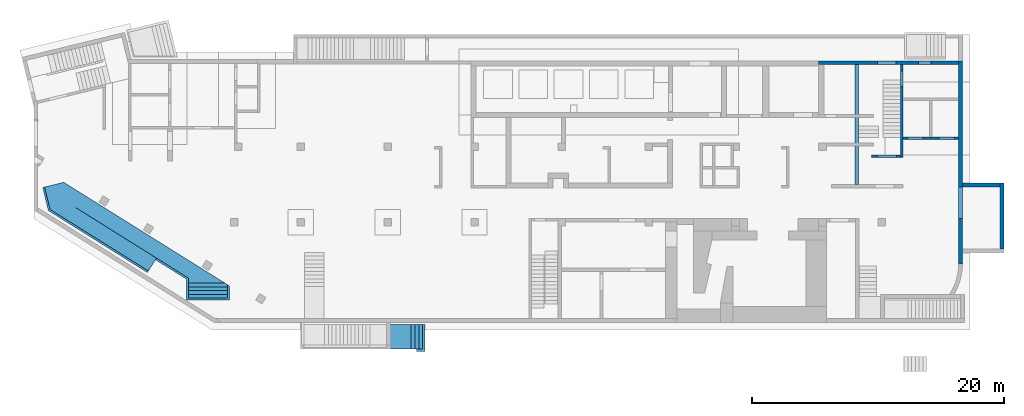
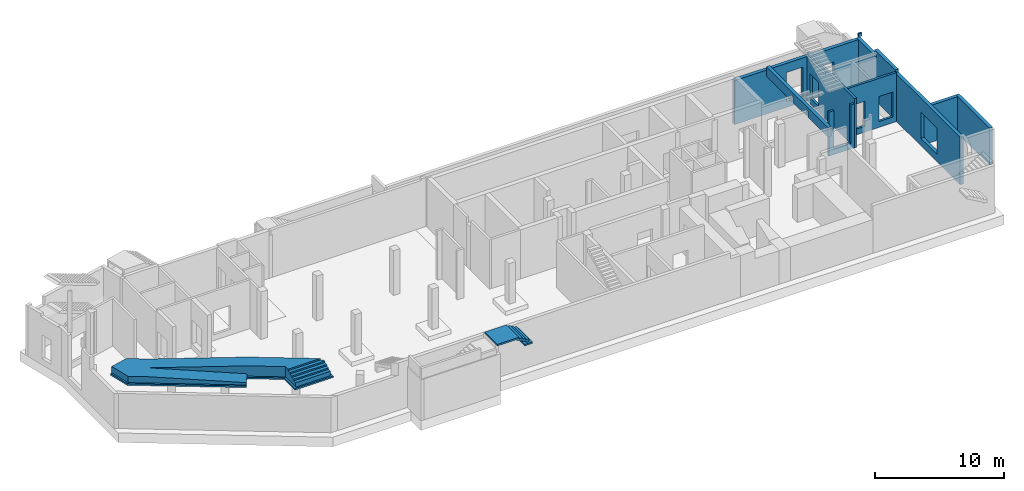
# One storey, part 8 of 9: 8 walls, 2 stairs, 6 openings.
"""IFC4 building model written with IfcOpenShell, lengths in millimetres."""

import ifcopenshell
import ifcopenshell.guid

model = None  # the IFC model being written
_history = None  # IfcOwnerHistory: only IFC2X3 demands one
_inside = {}  # id of a spatial element -> (the spatial element, [elements in it])
_under = {}  # id of a project, library or spatial element -> (it, [spatial elements below it])
_declared = {}  # id of a project -> (the project, [libraries it declares])
_typed = {}  # id of a type object -> (the type object, [elements of that type])
_made_of = {}  # id of a material, layer set ... -> (it, [elements and type objects made of it])


def new_model(schema):
    """Start an empty IFC model of exactly this schema.

    Asked for "IFC4X3", IfcOpenShell would pick the latest addendum, in which some entities
    have other attributes; the version numbers below select the first issue.
    IFC2X3 requires an IfcOwnerHistory on every rooted entity: one is made here for all.
    """
    global model, _history
    if schema == "IFC4X3":
        model = ifcopenshell.file(schema_version=(4, 3, 0, 0))
    else:
        model = ifcopenshell.file(schema=schema)
    _inside.clear()
    _under.clear()
    _declared.clear()
    _typed.clear()
    _made_of.clear()
    _history = None
    if model.schema == "IFC2X3":
        org = make("IfcOrganization", Name="unknown")
        user = make(
            "IfcPersonAndOrganization",
            ThePerson=make("IfcPerson", FamilyName="unknown"),
            TheOrganization=org,
        )
        app = make(
            "IfcApplication",
            ApplicationDeveloper=org,
            Version="unknown",
            ApplicationFullName="unknown",
            ApplicationIdentifier="unknown",
        )
        _history = make(
            "IfcOwnerHistory",
            OwningUser=user,
            OwningApplication=app,
            ChangeAction="ADDED",
            CreationDate=0,
        )
    return model


def make(cls, **values):
    """One entity of the class cls with the attributes given. An attribute that is None is left unset."""
    return model.create_entity(
        cls, **{name: value for name, value in values.items() if value is not None}
    )


def entity(cls, *values):
    """Any entity or typed value of the class cls, its attributes in the order of the schema. None: left unset."""
    e = model.create_entity(cls)
    for i, value in enumerate(values):
        if value is not None:
            e[i] = value
    return e


def rooted(cls, **values):
    """An entity with a GlobalId (a new one), such as an element, a storey or a relation."""
    return make(cls, GlobalId=ifcopenshell.guid.new(), OwnerHistory=_history, **values)


def si_unit(unit_type, name, prefix=None):
    """IfcSIUnit, for example si_unit("LENGTHUNIT", "METRE", prefix="MILLI")."""
    return make("IfcSIUnit", UnitType=unit_type, Prefix=prefix, Name=name)


def converted_unit(unit_type, name, factor, base, dimensions=None, offset=None):
    """IfcConversionBasedUnit, such as the inch: factor (a typed value) times the base unit."""
    return make(
        "IfcConversionBasedUnit"
        if offset is None
        else "IfcConversionBasedUnitWithOffset",
        ConversionOffset=offset,
        Dimensions=None
        if dimensions is None
        else entity("IfcDimensionalExponents", *dimensions),
        UnitType=unit_type,
        Name=name,
        ConversionFactor=make(
            "IfcMeasureWithUnit", ValueComponent=factor, UnitComponent=base
        ),
    )


def derived_unit(unit_type, elements):
    """IfcDerivedUnit: a product of units, each with its exponent."""
    return make(
        "IfcDerivedUnit",
        Elements=[
            make("IfcDerivedUnitElement", Unit=unit, Exponent=power)
            for unit, power in elements
        ],
        UnitType=unit_type,
    )


def assignment(units):
    """IfcUnitAssignment: the units of a project."""
    return None if units is None else make("IfcUnitAssignment", Units=units)


def point(xyz):
    """IfcCartesianPoint."""
    return None if xyz is None else make("IfcCartesianPoint", Coordinates=xyz)


def direction(xyz):
    """IfcDirection."""
    return None if xyz is None else make("IfcDirection", DirectionRatios=xyz)


def frame(location, z_axis=None, x_axis=None):
    """IfcAxis2Placement3D, a coordinate frame: its origin and axes. An axis left out is left unset."""
    return make(
        "IfcAxis2Placement3D",
        Location=point(location),
        Axis=direction(z_axis),
        RefDirection=direction(x_axis),
    )


def origin():
    """The frame at (0, 0, 0) with its axes left unset."""
    return frame((0.0, 0.0, 0.0))


def place(relative_to, where):
    """IfcLocalPlacement: puts the frame where relative to a parent placement (None: the world)."""
    return make(
        "IfcLocalPlacement", PlacementRelTo=relative_to, RelativePlacement=where
    )


def context(
    kind, dimensions, precision=None, world=None, true_north=None, identifier=None
):
    """IfcGeometricRepresentationContext, for example the 3D "Model" context."""
    return make(
        "IfcGeometricRepresentationContext",
        ContextIdentifier=identifier,
        ContextType=kind,
        CoordinateSpaceDimension=dimensions,
        Precision=precision,
        WorldCoordinateSystem=world,
        TrueNorth=true_north,
    )


def subcontext(parent, identifier, kind, view, scale=None):
    """IfcGeometricRepresentationSubContext, for example "Body" below "Model"."""
    return make(
        "IfcGeometricRepresentationSubContext",
        ContextIdentifier=identifier,
        ContextType=kind,
        ParentContext=parent,
        TargetScale=scale,
        TargetView=view,
    )


def project(units=None, contexts=None):
    """IfcProject with its units and contexts."""
    return rooted(
        "IfcProject",
        Name="project",
        RepresentationContexts=contexts,
        UnitsInContext=assignment(units),
    )


def spatial(cls, under=None, at=None, **own):
    """A site, building, storey or space (cls), placed at a placement, below another one or the project."""
    s = rooted(cls, ObjectPlacement=at, **own)
    if under is not None:
        _under.setdefault(under.id(), (under, []))[1].append(s)
    return s


def point_list(points):
    """IfcCartesianPointList2D or 3D."""
    cls = (
        "IfcCartesianPointList2D" if len(points[0]) == 2 else "IfcCartesianPointList3D"
    )
    return make(cls, CoordList=points)


def indexed_curve(points, segments=None, self_intersect=None):
    """IfcIndexedPolyCurve: lines and arcs through numbered points (the first is 1)."""
    return make(
        "IfcIndexedPolyCurve",
        Points=point_list(points),
        Segments=segments,
        SelfIntersect=self_intersect,
    )


def outline(outer, holes=None, kind="AREA"):
    """IfcArbitraryClosedProfileDef: a profile drawn as a closed curve; with holes, ...WithVoids."""
    if holes is None:
        return make("IfcArbitraryClosedProfileDef", ProfileType=kind, OuterCurve=outer)
    return make(
        "IfcArbitraryProfileDefWithVoids",
        ProfileType=kind,
        OuterCurve=outer,
        InnerCurves=holes,
    )


def extrude(swept, where, along, depth):
    """IfcExtrudedAreaSolid: the profile swept, set in the frame where, extruded along a direction by depth."""
    return make(
        "IfcExtrudedAreaSolid",
        SweptArea=swept,
        Position=where,
        ExtrudedDirection=direction(along),
        Depth=depth,
    )


def polygons(points, faces, closed=None, point_numbers=None):
    """IfcPolygonalFaceSet: a face is its outer loop, then its inner loops; points numbered from 1."""
    made = []
    for loops in faces:
        if len(loops) == 1:
            made.append(make("IfcIndexedPolygonalFace", CoordIndex=loops[0]))
        else:
            made.append(
                make(
                    "IfcIndexedPolygonalFaceWithVoids",
                    CoordIndex=loops[0],
                    InnerCoordIndices=loops[1:],
                )
            )
    return make(
        "IfcPolygonalFaceSet",
        Coordinates=point_list(points),
        Closed=closed,
        Faces=made,
        PnIndex=point_numbers,
    )


def shape(context_of_items, identifier, shape_type, items):
    """IfcShapeRepresentation: the items that make up one representation, for example the "Body"."""
    return make(
        "IfcShapeRepresentation",
        ContextOfItems=context_of_items,
        RepresentationIdentifier=identifier,
        RepresentationType=shape_type,
        Items=items,
    )


def material(Name=None, Category=None):
    """IfcMaterial."""
    return make("IfcMaterial", Name=Name, Category=Category)


def made_of(thing, what):
    """Note that an element or type object is made of a material, layer set ...; save() writes the relation."""
    if what is not None:
        _made_of.setdefault(what.id(), (what, []))[1].append(thing)
    return thing


def type_object(cls, material=None, **own):
    """A type object (cls), such as IfcWallType, which elements share."""
    return made_of(rooted(cls, **own), material)


def element(
    cls,
    number,
    at=None,
    inside=None,
    cuts=None,
    type_object=None,
    material=None,
    context=None,
    identifier="Body",
    shape_type=None,
    held_by="IfcProductDefinitionShape",
    body=None,
    shapes=None,
    **own,
):
    """One element of the class cls, such as IfcWall. Its Tag is "e" and its number.

    at: its placement. inside: the storey or other place that contains it. cuts: it is an
    opening in that element (IfcRelVoidsElement). A single representation is given by context,
    identifier, shape_type and body (its items); several are given by shapes. held_by: the class
    of the entity that holds the representations. save() writes the other relations.
    """
    e = rooted(cls, Tag="e%d" % number, ObjectPlacement=at, **own)
    if body is not None:
        shapes = [shape(context, identifier, shape_type, body)]
    if shapes is not None:
        e.Representation = make(held_by, Representations=shapes)
    if inside is not None:
        _inside.setdefault(inside.id(), (inside, []))[1].append(e)
    if cuts is not None:
        rooted(
            "IfcRelVoidsElement", RelatingBuildingElement=cuts, RelatedOpeningElement=e
        )
    if type_object is not None:
        _typed.setdefault(type_object.id(), (type_object, []))[1].append(e)
    return made_of(e, material)


def aggregate(whole, parts):
    """IfcRelAggregates: a whole, such as a stair, and the parts it consists of."""
    return rooted("IfcRelAggregates", RelatingObject=whole, RelatedObjects=parts)


def save(model, path):
    """Write the relations noted so far, then the file.

    IfcRelAggregates (storeys below a building ...), IfcRelContainedInSpatialStructure (elements
    in a storey), IfcRelDefinesByType, IfcRelAssociatesMaterial and IfcRelDeclares: one each for
    every whole, place, type object, material and project.
    """
    for whole, parts in _under.values():
        aggregate(whole, parts)
    for where, things in _inside.values():
        rooted(
            "IfcRelContainedInSpatialStructure",
            RelatedElements=things,
            RelatingStructure=where,
        )
    for kind, things in _typed.values():
        rooted("IfcRelDefinesByType", RelatedObjects=things, RelatingType=kind)
    for what, things in _made_of.values():
        rooted("IfcRelAssociatesMaterial", RelatedObjects=things, RelatingMaterial=what)
    for by, libraries in _declared.values():
        rooted("IfcRelDeclares", RelatingContext=by, RelatedDefinitions=libraries)
    model.write(path)


model = new_model("IFC4")

# Units and contexts
model_context = context("Model", 3, precision=0.01, world=origin(), true_north=direction((6.12303176911189e-17, 1.0)))
plan_context = context("Plan", 3, precision=0.01, world=origin(), true_north=direction((6.12303176911189e-17, 1.0)))
body_context = subcontext(model_context, "Body", "Model", "MODEL_VIEW")
ifc_project = project(units=[si_unit("LENGTHUNIT", "METRE", prefix="MILLI"), si_unit("AREAUNIT", "SQUARE_METRE"), si_unit("VOLUMEUNIT", "CUBIC_METRE"), converted_unit("PLANEANGLEUNIT", "DEGREE", entity("IfcRatioMeasure", 0.0174532925199433), si_unit("PLANEANGLEUNIT", "RADIAN"), dimensions=[0, 0, 0, 0, 0, 0, 0]), si_unit("MASSUNIT", "GRAM", prefix="KILO"), derived_unit("MASSDENSITYUNIT", [(si_unit("MASSUNIT", "GRAM", prefix="KILO"), 1), (si_unit("LENGTHUNIT", "METRE"), -3)]), derived_unit("MOMENTOFINERTIAUNIT", [(si_unit("LENGTHUNIT", "METRE"), 4)]), si_unit("TIMEUNIT", "SECOND"), si_unit("FREQUENCYUNIT", "HERTZ"), si_unit("THERMODYNAMICTEMPERATUREUNIT", "DEGREE_CELSIUS"), derived_unit("THERMALTRANSMITTANCEUNIT", [(si_unit("MASSUNIT", "GRAM", prefix="KILO"), 1), (si_unit("THERMODYNAMICTEMPERATUREUNIT", "KELVIN"), -1), (si_unit("TIMEUNIT", "SECOND"), -3)]), derived_unit("VOLUMETRICFLOWRATEUNIT", [(si_unit("LENGTHUNIT", "METRE"), 3), (si_unit("TIMEUNIT", "SECOND"), -1)]), derived_unit("MASSFLOWRATEUNIT", [(si_unit("MASSUNIT", "GRAM", prefix="KILO"), 1), (si_unit("TIMEUNIT", "SECOND"), -1)]), derived_unit("ROTATIONALFREQUENCYUNIT", [(si_unit("TIMEUNIT", "SECOND"), -1)]), si_unit("ELECTRICCURRENTUNIT", "AMPERE"), si_unit("ELECTRICVOLTAGEUNIT", "VOLT"), si_unit("POWERUNIT", "WATT"), si_unit("FORCEUNIT", "NEWTON", prefix="KILO"), si_unit("ILLUMINANCEUNIT", "LUX"), si_unit("LUMINOUSFLUXUNIT", "LUMEN"), si_unit("LUMINOUSINTENSITYUNIT", "CANDELA"), derived_unit("USERDEFINED", [(si_unit("MASSUNIT", "GRAM", prefix="KILO"), -1), (si_unit("LENGTHUNIT", "METRE"), -2), (si_unit("TIMEUNIT", "SECOND"), 3), (si_unit("LUMINOUSFLUXUNIT", "LUMEN"), 1)]), derived_unit("LINEARVELOCITYUNIT", [(si_unit("LENGTHUNIT", "METRE"), 1), (si_unit("TIMEUNIT", "SECOND"), -1)]), si_unit("PRESSUREUNIT", "PASCAL"), derived_unit("USERDEFINED", [(si_unit("LENGTHUNIT", "METRE"), -2), (si_unit("MASSUNIT", "GRAM", prefix="KILO"), 1), (si_unit("TIMEUNIT", "SECOND"), -2)]), derived_unit("LINEARFORCEUNIT", [(si_unit("MASSUNIT", "GRAM", prefix="KILO"), 1), (si_unit("LENGTHUNIT", "METRE"), 1), (si_unit("TIMEUNIT", "SECOND"), -2), (si_unit("LENGTHUNIT", "METRE"), -1)]), derived_unit("PLANARFORCEUNIT", [(si_unit("MASSUNIT", "GRAM", prefix="KILO"), 1), (si_unit("LENGTHUNIT", "METRE"), 1), (si_unit("TIMEUNIT", "SECOND"), -2), (si_unit("LENGTHUNIT", "METRE"), -2)])], contexts=[model_context, plan_context])

# Site, building, storey
site_placement = place(None, origin())
site = spatial("IfcSite", under=ifc_project, at=site_placement, CompositionType="ELEMENT")
building_placement = place(site_placement, origin())
building = spatial("IfcBuilding", under=site, at=building_placement, CompositionType="ELEMENT")
storey_placement = place(building_placement, frame((0.0, 0.0, -4900.0)))
storey = spatial("IfcBuildingStorey", under=building, at=storey_placement, CompositionType="ELEMENT", Elevation=-4900.0)

# Wall, openings
ifc_material_1 = material()
wall_type_1 = type_object("IfcWallType", PredefinedType="STANDARD")
wall_1_placement = place(storey_placement, frame((68970.0002685547, 14369.999226356, 0.0)))
wall_1 = element("IfcWall", 1, at=wall_1_placement, inside=storey, type_object=wall_type_1, material=ifc_material_1, PredefinedType="NOTDEFINED", context=body_context, shape_type="Tessellation", body=[
    polygons([(2.81053507844076e-12, -100.000000000001, 0.0), (4399.99999999999, -99.9999999999989, 0.0), (4399.99999999999, -99.9999999999989, 4650.0), (2.81053507844076e-12, -100.000000000001, 4650.0), (329.999999999988, -100.000000000003, 2919.99999999804), (1569.99999999999, -100.000000000001, 2919.99999999804), (1569.99999999999, -100.000000000001, 550.0), (329.999999999988, -100.000000000003, 550.0), (2829.99999999998, -100.000000000001, 2919.99999999804), (4069.99999999998, -100.000000000001, 2919.99999999804), (4069.99999999998, -100.000000000001, 550.0), (2829.99999999998, -100.000000000001, 550.0), (4399.99999999999, 99.9999999999989, 0.0), (2.12143781434178e-12, 99.9999999999968, 0.0), (2.12143781434178e-12, 99.9999999999968, 4650.0), (2099.99999999998, 99.9999999999989, 4650.0), (2299.99999999997, 99.9999999999968, 4650.0), (4399.99999999999, 99.9999999999989, 4650.0), (1569.99999999999, 99.9999999999989, 2919.99999999804), (329.999999999996, 99.9999999999968, 2919.99999999804), (329.999999999996, 99.9999999999968, 550.0), (1569.99999999999, 99.9999999999989, 550.0), (4069.99999999998, 99.9999999999989, 2919.99999999804), (2829.99999999998, 99.9999999999968, 2919.99999999804), (2829.99999999998, 99.9999999999968, 550.0), (4069.99999999998, 99.9999999999989, 550.0)], [[[1, 2, 3, 4], [5, 6, 7, 8], [9, 10, 11, 12]], [[13, 14, 15, 16, 17, 18], [19, 20, 21, 22], [23, 24, 25, 26]], [[2, 1, 14, 13]], [[4, 3, 18, 17, 16, 15]], [[3, 2, 13, 18]], [[1, 4, 15, 14]], [[5, 20, 19, 6]], [[6, 19, 22, 7]], [[7, 22, 21, 8]], [[20, 5, 8, 21]], [[23, 10, 9, 24]], [[12, 25, 24, 9]], [[25, 12, 11, 26]], [[26, 11, 10, 23]]], closed=True),
])
opening_1_placement = place(wall_1_placement, frame((-68970.0002685547, -14369.999226356, 0.0)))
element("IfcOpeningElement", 2, at=opening_1_placement, cuts=wall_1, PredefinedType="OPENING", context=body_context, shape_type="SweptSolid", body=[
    extrude(outline(indexed_curve([(-619.999999999998, -1184.99999999902), (620.000000000006, -1184.99999999902), (620.000000000006, 1184.99999999902), (-619.999999999998, 1184.99999999902), (-619.999999999998, -1184.99999999902)], self_intersect=False)), frame((69920.0002685547, 14169.999226354, 1735.0), z_axis=(0.0, 1.0, 0.0), x_axis=(1.0, 0.0, 0.0)), (0.0, 0.0, 1.0), 400.000000001943),
])
opening_2_placement = place(wall_1_placement, frame((-68970.0002685547, -14369.999226356, 0.0)))
element("IfcOpeningElement", 3, at=opening_2_placement, cuts=wall_1, PredefinedType="OPENING", context=body_context, shape_type="SweptSolid", body=[
    extrude(outline(indexed_curve([(-1184.99999999902, -619.999999999998), (1184.99999999902, -619.999999999998), (1184.99999999902, 619.999999999998), (-1184.99999999902, 619.999999999998), (-1184.99999999902, -619.999999999998)], self_intersect=False)), frame((72420.0002685547, 14169.9992263559, 1735.0), z_axis=(0.0, 1.0, 0.0), x_axis=(0.0, 0.0, -1.0)), (0.0, 0.0, 1.0), 400.000000001943),
])

# Wall, opening
wall_2_placement = place(storey_placement, frame((68870.0002685547, 20199.999226356, 0.0), z_axis=(0.0, 0.0, 1.0), x_axis=(0.0, -1.0, 0.0)))
wall_2 = element("IfcWall", 4, at=wall_2_placement, inside=storey, type_object=wall_type_1, material=ifc_material_1, PredefinedType="NOTDEFINED", context=body_context, shape_type="Tessellation", body=[
    polygons([(0.0, -100.000000000003, 0.0), (7169.99999999999, -99.9999999999902, 0.0), (7369.99999999999, -99.9999999999983, 0.0), (7369.99999999999, -99.9999999999983, 4170.0), (7369.99999999999, -99.9999999999983, 4650.0), (0.0, -100.000000000003, 4650.0), (0.0, -100.000000000003, 4420.0), (2830.00000000002, -100.000000000012, 4420.0), (2830.00000000002, -100.000000000012, 4170.0), (0.0, -100.000000000003, 4170.0), (500.000000000003, -100.000000000001, 2829.99999999805), (1750.0, -99.9999999999977, 2829.99999999804), (1750.0, -99.9999999999977, 550.0), (500.000000000003, -100.000000000001, 550.0), (7369.99999999999, 99.9999999999996, 0.0), (5930.00000000002, 100.000000000004, 0.0), (5730.00000000002, 100.000000000003, 0.0), (2830.00000000051, 100.000000000003, 0.0), (2630.00000000051, 100.000000000003, 0.0), (-4.33146851719357e-12, 100.000000000004, 0.0), (-4.33146851719357e-12, 100.000000000004, 4170.0), (2630.00000000051, 100.000000000003, 4170.0), (2830.00000000002, 100.000000000012, 4170.0), (2830.00000000002, 100.000000000012, 4420.0), (2630.00000000051, 100.000000000003, 4420.0), (-4.33146851719357e-12, 100.000000000004, 4420.0), (-4.33146851719357e-12, 100.000000000004, 4650.0), (2630.00000000051, 100.000000000003, 4650.0), (2830.00000000051, 100.000000000003, 4650.0), (5730.00000000002, 100.000000000003, 4650.0), (5930.00000000002, 100.000000000004, 4650.0), (7369.99999999999, 99.9999999999996, 4650.0), (1749.99999999999, 100.000000000009, 2829.99999999804), (499.999999999999, 100.000000000005, 2829.99999999805), (499.999999999999, 100.000000000005, 550.0), (1749.99999999999, 100.000000000009, 550.0)], [[[1, 2, 3, 4, 5, 6, 7, 8, 9, 10], [11, 12, 13, 14]], [[15, 16, 17, 18, 19, 20, 21, 22, 23, 24, 25, 26, 27, 28, 29, 30, 31, 32], [33, 34, 35, 36]], [[3, 2, 1, 20, 19, 18, 17, 16, 15]], [[6, 5, 32, 31, 30, 29, 28, 27]], [[5, 4, 3, 15, 32]], [[20, 1, 10, 21]], [[11, 34, 33, 12]], [[36, 13, 12, 33]], [[13, 36, 35, 14]], [[14, 35, 34, 11]], [[9, 23, 22, 21, 10]], [[24, 8, 7, 26, 25]], [[23, 9, 8, 24]], [[6, 27, 26, 7]]], closed=True),
])
opening_3_placement = place(wall_2_placement, frame((20199.999226356, -68870.0002685547, 0.0), z_axis=(0.0, 0.0, 1.0), x_axis=(0.0, 1.0, 0.0)))
element("IfcOpeningElement", 5, at=opening_3_placement, cuts=wall_2, PredefinedType="OPENING", context=body_context, shape_type="SweptSolid", body=[
    extrude(outline(indexed_curve([(-624.999999999999, -1139.99999999902), (624.999999999999, -1139.99999999902), (624.999999999999, 1139.99999999902), (-624.999999999999, 1139.99999999902), (-624.999999999999, -1139.99999999902)], self_intersect=False)), frame((68670.0002685528, 19074.999226356, 1690.0), z_axis=(1.0, 0.0, 0.0), x_axis=(0.0, -1.0, 0.0)), (0.0, 0.0, 1.0), 400.000000001936),
])

wall_3_placement = place(storey_placement, frame((68770.0002685547, 12929.999226356, 0.0), z_axis=(0.0, 0.0, 1.0), x_axis=(-1.0, 0.0, 0.0)))
wall_3 = element("IfcWall", 6, at=wall_3_placement, inside=storey, type_object=wall_type_1, material=ifc_material_1, PredefinedType="NOTDEFINED", context=body_context, shape_type="Tessellation", body=[
    polygons([(9.8127816513605e-13, -99.9999999999989, 0.0), (2300.00000000003, -99.9999999999989, 0.0), (2300.00000000003, -99.9999999999989, 4170.0), (1830.00000000004, -99.9999999999989, 4170.0), (1830.00000000004, -99.9999999999989, 550.0), (330.00000000003, -99.9999999999968, 550.0), (330.00000000003, -99.9999999999968, 4170.0), (9.8127816513605e-13, -99.9999999999989, 4170.0), (2300.00000000003, 100.000000000001, 0.0), (8.96430781706574e-12, 100.000000000001, 0.0), (8.96430781706574e-12, 100.000000000001, 4170.0), (330.000000000029, 100.000000000003, 4170.0), (330.000000000029, 100.000000000003, 550.0), (1830.00000000003, 100.000000000001, 550.0), (1830.00000000003, 100.000000000001, 4170.0), (2300.00000000003, 100.000000000001, 4170.0)], [[[1, 2, 3, 4, 5, 6, 7, 8]], [[9, 10, 11, 12, 13, 14, 15, 16]], [[2, 1, 10, 9]], [[3, 2, 9, 16]], [[3, 16, 15, 4]], [[1, 8, 11, 10]], [[14, 5, 4, 15]], [[5, 14, 13, 6]], [[6, 13, 12, 7]], [[11, 8, 7, 12]]], closed=True),
])
opening_4_placement = place(wall_3_placement, frame((68770.0002685547, 12929.999226356, 0.0), z_axis=(0.0, 0.0, 1.0), x_axis=(-1.0, 0.0, 0.0)))
element("IfcOpeningElement", 7, at=opening_4_placement, cuts=wall_3, PredefinedType="OPENING", context=body_context, shape_type="SweptSolid", body=[
    extrude(outline(indexed_curve([(-749.999999999994, -1809.99999999902), (750.000000000003, -1809.99999999902), (750.000000000003, 1809.99999999902), (-749.999999999994, 1809.99999999902), (-749.999999999994, -1809.99999999902)], self_intersect=False)), frame((67690.0002685547, 13129.9992263579, 2360.0), z_axis=(0.0, -1.0, 0.0), x_axis=(-1.0, 0.0, 0.0)), (0.0, 0.0, 1.0), 400.000000001943),
])

# Walls
wall_type_2 = type_object("IfcWallType", PredefinedType="STANDARD")
wall_4_placement = place(storey_placement, frame((73520.0002685546, 4399.9992263554, 0.0), z_axis=(0.0, 0.0, 1.0), x_axis=(0.0, 1.0, 0.0)))
element("IfcWall", 8, at=wall_4_placement, inside=storey, type_object=wall_type_2, material=ifc_material_1, PredefinedType="NOTDEFINED", context=body_context, shape_type="Tessellation", body=[
    polygons([(0.0, -149.999999999999, 0.0), (875.000000000547, -149.999999999997, 0.0), (1175.00000000055, -150.000000000005, 0.0), (6100.00000000051, -150.000000000002, 0.0), (6400.00000000052, -150.000000000001, 0.0), (16100.0000000005, -150.000000000004, 0.0), (16100.0000000005, -150.000000000004, 3300.0), (16100.0000000005, -150.000000000004, 3550.0), (16100.0000000005, -150.000000000004, 4170.0), (12970.0000000005, -150.000000000003, 4170.0), (12970.0000000005, -150.000000000003, 4420.0), (13275.0000000005, -150.000000000002, 4420.0), (13275.0000000005, -150.000000000002, 4750.0), (10070.0000000005, -150.000000000009, 4750.0), (10070.0000000005, -150.000000000009, 4500.0), (0.0, -149.999999999999, 4500.0), (3600.00000000052, -149.999999999999, 3199.99999999804), (6100.00000000051, -150.000000000002, 3199.99999999804), (6100.00000000051, -150.000000000002, 700.0), (3600.00000000052, -149.999999999999, 700.0), (16100.0000000005, 149.999999999997, 0.0), (15800.0000000005, 149.999999999997, 0.0), (13170.0, 149.999999999999, 0.0), (12970.0, 149.999999999998, 0.0), (10070.0000000005, 150.0, 0.0), (9870.00000000053, 150.0, 0.0), (0.0, 150.000000000002, 0.0), (0.0, 150.000000000002, 4500.0), (10070.0000000005, 149.999999999992, 4500.0), (10070.0000000005, 149.999999999992, 4750.0), (13275.0000000005, 149.999999999999, 4750.0), (13275.0000000005, 149.999999999999, 4420.0), (13170.0, 149.999999999999, 4420.0), (12970.0000000005, 149.999999999998, 4420.0), (12970.0000000005, 149.999999999998, 4170.0), (13170.0, 149.999999999999, 4170.0), (15800.0000000005, 149.999999999997, 4170.0), (16100.0000000005, 149.999999999997, 4170.0), (16100.0000000005, 149.999999999997, 3300.0), (6100.00000000051, 149.999999999999, 3199.99999999804), (3600.00000000052, 150.000000000002, 3199.99999999804), (3600.00000000052, 150.000000000002, 700.0), (6100.00000000051, 149.999999999999, 700.0), (13275.0000000006, -49.99999999999, 4750.0)], [[[1, 2, 3, 4, 5, 6, 7, 8, 9, 10, 11, 12, 13, 14, 15, 16], [17, 18, 19, 20]], [[21, 22, 23, 24, 25, 26, 27, 28, 29, 30, 31, 32, 33, 34, 35, 36, 37, 38, 39], [40, 41, 42, 43]], [[6, 5, 4, 3, 2, 1, 27, 26, 25, 24, 23, 22, 21]], [[27, 1, 16, 28]], [[35, 10, 9, 38, 37, 36]], [[10, 35, 34, 11]], [[17, 41, 40, 18]], [[43, 19, 18, 40]], [[19, 43, 42, 20]], [[20, 42, 41, 17]], [[15, 29, 28, 16]], [[29, 15, 14, 30]], [[6, 21, 39, 38, 9, 8, 7]], [[13, 12, 32, 31, 44]], [[11, 34, 33, 32, 12]], [[13, 44, 31, 30, 14]]], closed=True),
    polygons([(15900.0000000005, -150.000000000004, 4750.0), (15900.0000000005, 149.999999999997, 4750.0), (15775.0000000006, 149.999999999997, 4750.0), (15775.0000000006, -49.9999999999927, 4750.0), (15775.0000000006, -150.000000000005, 4750.0), (15900.0000000005, -150.000000000004, 4420.0), (15775.0000000006, -150.000000000005, 4420.0), (15775.0000000006, 149.999999999997, 4420.0), (15900.0000000005, 149.999999999997, 4420.0)], [[[1, 2, 3, 4, 5]], [[6, 7, 8, 9]], [[2, 1, 6, 9]], [[7, 5, 4, 3, 8]], [[2, 9, 8, 3]], [[7, 6, 1, 5]]], closed=True),
])
wall_5_placement = place(storey_placement, frame((76820.0002685546, 5574.99922635594, 0.0), z_axis=(0.0, 0.0, 1.0), x_axis=(0.0, 1.0, 0.0)))
element("IfcWall", 9, at=wall_5_placement, inside=storey, type_object=wall_type_2, material=ifc_material_1, PredefinedType="NOTDEFINED", context=body_context, shape_type="Tessellation", body=[
    polygons([(0.0, -149.999999999992, 0.0), (5224.99999999998, -150.000000000001, 0.0), (5224.99999999998, -150.000000000001, 3500.0), (0.0, -149.999999999992, 3500.0), (1.08286712929839e-12, 150.000000000009, 0.0), (1.08286712929839e-12, 150.000000000009, 3500.0), (4924.99999999998, 150.0, 3500.0), (5225.0, 150.0, 3500.0), (5224.99999999998, 150.0, 0.0), (4924.99999999998, 150.0, 0.0)], [[[1, 2, 3, 4]], [[5, 6, 7, 8, 9, 10]], [[2, 1, 5, 10, 9]], [[1, 4, 6, 5]], [[3, 2, 9, 8]], [[4, 3, 8, 7, 6]]], closed=True),
])
wall_6_placement = place(storey_placement, frame((76670.0002685547, 10649.9992263559, 0.0), z_axis=(0.0, 0.0, 1.0), x_axis=(-1.0, 0.0, 0.0)))
element("IfcWall", 10, at=wall_6_placement, inside=storey, type_object=wall_type_2, material=ifc_material_1, PredefinedType="NOTDEFINED", context=body_context, shape_type="Tessellation", body=[
    polygons([(0.0, -150.000000000001, 0.0), (2400.0, -150.000000000001, 0.0), (2999.99999999999, -150.000000000001, 0.0), (2999.99999999999, -150.000000000001, 3500.0), (0.0, -150.000000000001, 3500.0), (0.0, 150.000000000001, 0.0), (0.0, 150.000000000001, 3500.0), (2999.99999999999, 150.000000000001, 3500.0), (2999.99999999999, 150.000000000001, 3199.99999999804), (2999.99999999999, 150.000000000001, 700.0), (2999.99999999999, 150.000000000001, 0.0)], [[[1, 2, 3, 4, 5]], [[6, 7, 8, 9, 10, 11]], [[3, 2, 1, 6, 11]], [[1, 5, 7, 6]], [[4, 3, 11, 10, 9, 8]], [[5, 4, 8, 7]]], closed=True),
])

# Wall, openings
wall_7_placement = place(storey_placement, frame((73370.0002685547, 20349.9992263559, 0.0), z_axis=(0.0, 0.0, 1.0), x_axis=(-1.0, 0.0, 0.0)))
wall_7 = element("IfcWall", 11, at=wall_7_placement, inside=storey, type_object=wall_type_2, material=ifc_material_1, PredefinedType="NOTDEFINED", context=body_context, shape_type="Tessellation", body=[
    polygons([(-2.63247301876675e-12, -150.000000000001, 0.0), (11100.0, -150.000000000001, 0.0), (11100.0, -150.000000000001, 4170.0), (10700.0, -150.000000000005, 4170.0), (-2.63247301876675e-12, -150.000000000001, 4170.0), (2195.00000000001, -150.000000000005, 2829.99999999804), (3195.00000000001, -150.000000000005, 2829.99999999805), (3195.00000000001, -150.000000000005, 550.0), (2195.00000000001, -150.000000000005, 550.0), (4950.00000000001, -150.000000000005, 3299.99999999804), (6450.00000000001, -150.000000000005, 3299.99999999805), (6450.00000000001, -150.000000000005, 550.0), (4950.00000000001, -150.000000000005, 550.0), (11100.0, 150.000000000001, 0.0), (10700.0, 149.999999999996, 0.0), (4599.99999999997, 149.999999999996, 0.0), (4399.99999999997, 149.999999999996, 0.0), (-4.49556941830264e-12, 150.000000000001, 0.0), (-4.49556941830264e-12, 150.000000000001, 4170.0), (4399.99999999997, 149.999999999996, 4170.0), (4599.99999999997, 149.999999999996, 4170.0), (10700.0, 149.999999999996, 4170.0), (11100.0, 150.000000000001, 4170.0), (6450.00000000002, 149.999999999996, 3299.99999999805), (4950.00000000001, 149.999999999996, 3299.99999999804), (4950.00000000001, 149.999999999996, 550.0), (6450.00000000002, 149.999999999996, 550.0), (3195.00000000001, 149.999999999996, 2829.99999999805), (2195.00000000001, 149.999999999996, 2829.99999999804), (2195.00000000001, 149.999999999996, 550.0), (3195.00000000001, 149.999999999996, 550.0)], [[[1, 2, 3, 4, 5], [6, 7, 8, 9], [10, 11, 12, 13]], [[14, 15, 16, 17, 18, 19, 20, 21, 22, 23], [24, 25, 26, 27], [28, 29, 30, 31]], [[2, 1, 18, 17, 16, 15, 14]], [[5, 4, 3, 23, 22, 21, 20, 19]], [[3, 2, 14, 23]], [[24, 11, 10, 25]], [[25, 10, 13, 26]], [[26, 13, 12, 27]], [[11, 24, 27, 12]], [[28, 7, 6, 29]], [[9, 30, 29, 6]], [[30, 9, 8, 31]], [[31, 8, 7, 28]], [[5, 19, 18, 1]]], closed=True),
])
opening_5_placement = place(wall_7_placement, frame((73370.0002685547, 20349.9992263559, 0.0), z_axis=(0.0, 0.0, 1.0), x_axis=(-1.0, 0.0, 0.0)))
element("IfcOpeningElement", 12, at=opening_5_placement, cuts=wall_7, PredefinedType="OPENING", context=body_context, shape_type="SweptSolid", body=[
    extrude(outline(indexed_curve([(-1374.99999999902, -749.999999999994), (1374.99999999902, -749.999999999994), (1374.99999999902, 750.000000000003), (-1374.99999999902, 750.000000000003), (-1374.99999999902, -749.999999999994)], self_intersect=False)), frame((67670.0002685547, 20599.999226356, 1925.0), z_axis=(0.0, -1.0, 0.0), x_axis=(0.0, 0.0, -1.0)), (0.0, 0.0, 1.0), 500.000000001944),
])
opening_6_placement = place(wall_7_placement, frame((73370.0002685547, 20349.9992263559, 0.0), z_axis=(0.0, 0.0, 1.0), x_axis=(-1.0, 0.0, 0.0)))
element("IfcOpeningElement", 13, at=opening_6_placement, cuts=wall_7, PredefinedType="OPENING", context=body_context, shape_type="SweptSolid", body=[
    extrude(outline(indexed_curve([(-1139.99999999902, -499.999999999999), (1139.99999999902, -499.999999999999), (1139.99999999902, 499.999999999999), (-1139.99999999902, 499.999999999999), (-1139.99999999902, -499.999999999999)], self_intersect=False)), frame((70675.0002685547, 20599.999226356, 1690.0), z_axis=(0.0, -1.0, 0.0), x_axis=(0.0, 0.0, -1.0)), (0.0, 0.0, 1.0), 500.000000001939),
])

# Wall
wall_8_placement = place(storey_placement, frame((65280.0002685546, 10675.0, 3600.0), z_axis=(0.0, 0.0, 1.0), x_axis=(0.0, 1.0, 0.0)))
element("IfcWall", 14, at=wall_8_placement, inside=storey, type_object=wall_type_2, material=ifc_material_1, PredefinedType="NOTDEFINED", context=body_context, shape_type="Tessellation", body=[
    polygons([(0.0, -150.000000000001, 900.0), (0.0, -150.000000000001, 570.0), (0.0, -150.000000000001, 0.0), (3074.99922635569, -150.000000000001, 0.0), (3074.99922635569, -150.000000000001, 570.0), (3324.99922635569, -150.000000000001, 570.0), (3324.99922635569, -150.000000000001, 0.0), (5324.99922635551, -150.000000000001, 0.0), (5324.99922635551, -150.000000000001, 570.0), (5574.99922635551, -150.000000000001, 570.0), (5574.99922635551, -150.000000000001, 0.0), (9524.9992263555, -150.000000000001, 0.0), (9524.9992263555, -150.000000000009, 900.0), (3794.99922635547, -150.000000000001, 900.0), (2.16573425859679e-12, 150.000000000001, 900.0), (9524.9992263555, 150.000000000001, 900.0), (9524.9992263555, 150.000000000001, 0.0), (5574.99922635551, 150.000000000001, 0.0), (5574.99922635551, 150.000000000001, 570.0), (5324.99922635551, 150.000000000001, 570.0), (5324.99922635551, 150.000000000001, 0.0), (3324.99922635569, 150.000000000001, 0.0), (3324.99922635569, 150.000000000001, 570.0), (3074.9992263557, 150.000000000001, 570.0), (3074.99922635569, 150.000000000001, 0.0), (2.16573425859679e-12, 150.000000000001, 0.0)], [[[1, 2, 3, 4, 5, 6, 7, 8, 9, 10, 11, 12, 13, 14]], [[15, 16, 17, 18, 19, 20, 21, 22, 23, 24, 25, 26]], [[3, 26, 25, 4]], [[3, 2, 1, 15, 26]], [[16, 15, 1, 14, 13]], [[13, 12, 17, 16]], [[5, 4, 25, 24]], [[7, 6, 23, 22]], [[10, 19, 18, 11]], [[20, 9, 8, 21]], [[19, 10, 9, 20]], [[5, 24, 23, 6]], [[7, 22, 21, 8]], [[17, 12, 11, 18]]], closed=True),
])

# Stairs
ifc_material_2 = material()
stair_type_1 = type_object("IfcStairType", PredefinedType="HALF_TURN_STAIR")
stair_1_placement = place(storey_placement, frame((27990.0002685546, -2550.00077364374, 4000.0)))
element("IfcStair", 15, at=stair_1_placement, inside=storey, type_object=stair_type_1, material=ifc_material_2, PredefinedType="HALF_TURN_STAIR", context=body_context, shape_type="Tessellation", body=[
    polygons([(2350.0, 2.16573425859679e-12, 149.999999999999), (2350.0, 2.16573425859679e-12, 0.0), (3050.0, 0.0, 2.16573425859679e-12), (3050.0, 0.0, 150.000000000002), (3050.00000000001, 2150.0, 150.000000000002), (3050.00000000001, 2150.0, 2.16573425859679e-12), (2350.00000000001, 2150.0, 0.0), (2350.00000000001, 2150.0, 149.999999999999), (2610.0, 2150.0, 150.000000000001), (2610.0, 2150.0, 202.294901687517), (1614.58980337503, 2150.0, 700.0), (4.33146851719357e-12, 2150.00000000001, 699.999999999994), (4.33146851719357e-12, 2150.00000000001, 849.999999999994), (1950.00000000001, 2150.0, 849.999999999994), (1950.00000000001, 2150.0, 700.0), (2250.00000000001, 2150.0, 700.000000000001), (2250.00000000001, 2150.0, 550.000000000001), (2550.00000000001, 2150.0, 550.000000000001), (2550.00000000001, 2150.0, 400.000000000001), (2850.00000000001, 2150.0, 400.000000000001), (2850.0, 2150.0, 150.000000000001), (2850.0, 200.0, 150.000000000001), (2610.0, 200.000000000001, 150.000000000001), (1950.0, 200.000000000004, 849.999999999994), (0.0, 200.000000000009, 849.999999999994), (0.0, 200.000000000009, 699.999999999994), (1614.58980337503, 200.000000000004, 700.0), (2610.0, 200.000000000001, 202.294901687517), (2850.0, 200.0, 400.000000000001), (2550.0, 200.000000000001, 400.000000000001), (2550.0, 200.000000000001, 550.000000000001), (2250.0, 200.000000000002, 550.000000000001), (2250.0, 200.000000000002, 700.000000000001), (1950.0, 200.000000000004, 700.0)], [[[1, 2, 3, 4]], [[5, 6, 7, 8, 9, 10, 11, 12, 13, 14, 15, 16, 17, 18, 19, 20, 21]], [[1, 4, 5, 21, 22, 23, 9, 8]], [[4, 3, 6, 5]], [[3, 2, 7, 6]], [[2, 1, 8, 7]], [[24, 25, 26, 27, 28, 23, 22, 29, 30, 31, 32, 33, 34]], [[24, 34, 15, 14]], [[34, 33, 16, 15]], [[33, 32, 17, 16]], [[32, 31, 18, 17]], [[31, 30, 19, 18]], [[30, 29, 20, 19]], [[29, 22, 21, 20]], [[23, 28, 10, 9]], [[28, 27, 11, 10]], [[27, 26, 12, 11]], [[26, 25, 13, 12]], [[25, 24, 14, 13]]], closed=True),
])
stair_type_2 = type_object("IfcStairType", PredefinedType="HALF_TURN_STAIR")
stair_2_placement = place(storey_placement, frame((706.267459667013, 1524.99922635635, 3730.0)))
element("IfcStair", 16, at=stair_2_placement, inside=storey, type_object=stair_type_2, material=ifc_material_2, PredefinedType="HALF_TURN_STAIR", context=body_context, shape_type="Tessellation", body=[
    polygons([(579.732808887634, 7186.00869393675, 750.000000000001), (1851.81192455399, 6391.1409543187, 750.000000000001), (2487.70611624843, 7408.80424685179, 750.0), (3123.60030794287, 8426.46753938488, 750.000000000001), (1666.69514343611, 9336.82515840979, 750.000000000001), (145.750531009357, 8966.00181001227, 750.000000000001), (1931.2986985158, 6518.34886588534, 600.000000000001), (711.000745367871, 7280.86077550907, 600.000000000001), (327.012520496049, 8855.80157785586, 600.000000000001), (1640.81431872975, 9176.12118579633, 600.000000000001), (3044.11353398106, 8299.25962781825, 600.000000000001), (579.732808887639, 7186.00869393675, 150.000000000001), (8381.8180516413, 2310.81989094609, 150.000000000001), (8381.8180516413, 2310.81989094609, 369.999999999997), (1666.69514343611, 9336.82515840979, 0.0), (4.06075173486897e-13, 8930.55058390988, 0.0), (4.06075173486897e-13, 8930.55058390988, 150.000000000001), (145.732808887646, 8966.074497899, 150.000000000001), (448.464872407401, 7091.15661236443, 150.000000000001), (8302.33127767949, 2183.61197937946, 150.000000000001), (2281.01143071999, 7361.08310924696, 0.0), (2519.4717526054, 7742.70684394687, 0.0), (11843.7328088876, 1916.37558975191, 0.0), (11843.7328088876, 450.000000000011, 0.0), (14373.7328088876, 450.000000000002, 0.0), (14373.7328088876, 1072.10840588886, 0.0), (1648.45406369317, 9023.58990388021, 0.0), (508.274509982748, 8745.60134569946, 0.0), (842.268681848117, 7375.71285708139, 0.0), (8540.79159956491, 2565.23571407936, 0.0), (8302.33127767949, 2183.61197937946, 0.0), (448.464872407401, 7091.15661236443, 0.0), (14823.7328088876, 1115.55600902313, 0.0), (14823.7328088876, 8.12150346973795e-13, 0.0), (11393.7328088876, 1.21822552046069e-11, 0.0), (11393.7328088876, 1666.93393689869, 0.0), (2281.01143071999, 7361.08310924696, 150.000000000001), (11393.7328088876, 1666.93393689869, 150.000000000001), (2519.4717526054, 7742.70684394687, 150.000000000001), (11843.7328088876, 1916.37558975191, 150.000000000001), (9017.71224333574, 3328.48318347918, 1120.0), (9017.71224333574, 3328.48318347918, 369.999999999997), (9017.71224333574, 3328.48318347918, 219.817449587824), (2487.70611624843, 7408.80424685179, 599.817449587827), (2487.70611624843, 7408.80424685179, 149.999999999984), (11543.7328088876, 1750.08115451642, 150.000000000001), (11543.7328088876, 1750.08115451643, 1120.0), (11693.7328088876, 1833.22837213415, 150.000000000001), (2567.19289021024, 7536.01215841843, 149.999999999984), (2567.19289021024, 7536.01215841843, 599.826925620747), (9097.19901729755, 3455.69109504581, 969.826925620748), (9097.19901729755, 3455.69109504581, 970.0), (11693.7328088876, 1833.22837213415, 970.0), (1931.2986985158, 6518.34886588534, 599.817449587827), (3044.11353398106, 8299.25962781825, 599.826925620767), (9653.60643503017, 4346.14647601226, 1120.0), (14448.5366726619, 1350.0, 1120.0), (14448.5366726619, 1350.0, 980.0), (14673.7328088876, 1209.28458256413, 979.999999999992), (14673.7328088876, 1209.28458256413, 150.000000000001), (14823.7328088876, 1115.55600902313, 150.0), (14448.5366726619, 1350.0, 814.470546427522), (14448.5366726619, 1350.0, 150.000000000001), (14523.7328088876, 1303.01315610513, 150.000000000001), (14523.7328088876, 1303.01315610513, 792.543352609913), (9574.11966106838, 4218.93856444562, 969.826925620765), (1640.81431872975, 9176.12118579633, 150.000000000001), (14165.4707123952, 1350.0, 150.000000000001), (14165.4707123952, 1350.0, 814.470546427524), (13632.1049714241, 1683.2774005124, 970.0), (9574.11966106839, 4218.93856444561, 970.0), (842.268681848117, 7375.71285708139, 150.000000000001), (8540.79159956491, 2565.23571407936, 150.000000000001), (508.274509982748, 8745.60134569946, 150.000000000001), (1648.45406369317, 9023.58990388021, 150.000000000001), (14373.7328088876, 1072.10840588886, 150.000000000001), (711.000745367872, 7280.86077550907, 150.000000000001), (8461.30482560311, 2438.02780251273, 219.817449587832), (8461.30482560311, 2438.02780251273, 150.000000000001), (327.012520496048, 8855.80157785586, 150.000000000001), (11543.7328088876, 1350.00000000001, 1120.0), (11693.7328088876, 1683.2774005124, 970.0), (11543.7328088876, 150.000000000063, 149.999999999976), (11543.7328088876, 150.000000000038, 559.999999999926), (11543.7328088876, 450.000000000037, 559.999999999945), (11543.7328088876, 450.000000000028, 699.999999999945), (11543.7328088876, 750.000000000029, 699.999999999963), (11543.7328088876, 750.00000000002, 839.999999999963), (11543.7328088876, 1050.00000000002, 839.999999999982), (11543.7328088876, 1050.00000000001, 979.999999999982), (11543.7328088876, 1350.00000000001, 980.0), (11693.7328088876, 300.000000000052, 324.470546427467), (11693.7328088876, 300.00000000006, 149.999999999979), (14673.7328088876, 1050.00000000001, 979.999999999982), (14673.7328088876, 1050.00000000002, 839.999999999982), (14673.7328088876, 750.00000000002, 839.999999999963), (14673.7328088876, 750.000000000029, 699.999999999963), (14673.7328088876, 450.000000000028, 699.999999999945), (14673.7328088876, 450.000000000037, 559.999999999945), (14673.7328088876, 150.000000000038, 559.999999999926), (14673.7328088876, 150.000000000063, 149.999999999976), (14523.7328088876, 300.000000000052, 324.470546427467), (14523.7328088876, 300.000000000063, 149.999999999979), (14823.7328088876, 8.12150346973795e-13, 150.000000000001), (11393.7328088876, 1.19115384222823e-11, 150.000000000001), (14373.7328088876, 450.000000000002, 150.000000000001), (11843.7328088876, 450.000000000011, 150.000000000001)], [[[1, 2, 3, 4, 5, 6]], [[7, 8, 9, 10, 11]], [[2, 1, 12, 13, 14]], [[6, 5, 15, 16, 17, 18]], [[1, 6, 18, 12]], [[19, 20, 13, 12, 18, 17]], [[21, 22, 23, 24, 25, 26, 27, 28, 29, 30, 31, 32, 16, 15, 33, 34, 35, 36]], [[37, 21, 36, 38]], [[39, 40, 23, 22]], [[37, 39, 22, 21]], [[41, 3, 42, 43, 44, 45, 46, 47]], [[48, 49, 50, 51, 52, 53]], [[50, 49, 45, 44, 54, 7, 11, 55]], [[4, 56, 57, 58, 59, 60, 61, 33, 15, 5], [62, 63, 64, 65]], [[56, 4, 3, 41]], [[51, 50, 55, 66]], [[66, 55, 11, 10, 67, 68, 69, 70, 71]], [[20, 19, 32, 31]], [[72, 73, 30, 29]], [[74, 72, 29, 28]], [[75, 74, 28, 27]], [[75, 27, 26, 76]], [[19, 17, 16, 32]], [[77, 8, 7, 54, 78, 79]], [[8, 77, 80, 9]], [[9, 80, 67, 10]], [[54, 44, 43, 78]], [[2, 14, 42, 3]], [[47, 81, 57, 56, 41]], [[52, 71, 70, 82, 53]], [[81, 47, 46, 83, 84, 85, 86, 87, 88, 89, 90, 91]], [[57, 81, 91, 58]], [[48, 53, 82, 92, 93]], [[51, 66, 71, 52]], [[94, 95, 96, 97, 98, 99, 100, 101, 60, 59]], [[90, 94, 59, 58, 91]], [[70, 69, 62, 65, 102, 92, 82]], [[93, 92, 102, 103]], [[84, 83, 101, 100]], [[85, 84, 100, 99]], [[86, 85, 99, 98]], [[87, 86, 98, 97]], [[88, 87, 97, 96]], [[89, 88, 96, 95]], [[90, 89, 95, 94]], [[64, 103, 102, 65]], [[104, 105, 35, 34]], [[61, 104, 34, 33]], [[106, 76, 26, 25]], [[107, 106, 25, 24]], [[40, 107, 24, 23]], [[105, 38, 36, 35]], [[31, 30, 73, 79, 78, 43, 42, 14, 13, 20]], [[68, 63, 62, 69]], [[39, 37, 38, 105, 104, 61, 60, 101, 83, 46, 45, 49, 48, 93, 103, 64, 63, 68, 67, 80, 77, 79, 73, 72, 74, 75, 76, 106, 107, 40]]], closed=True),
])

save(model, "model.ifc")
